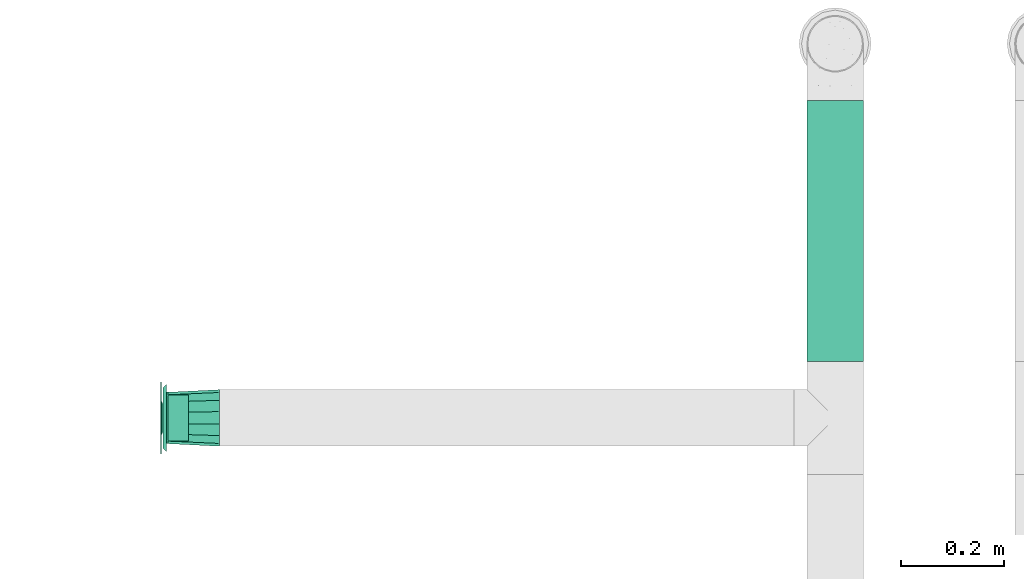
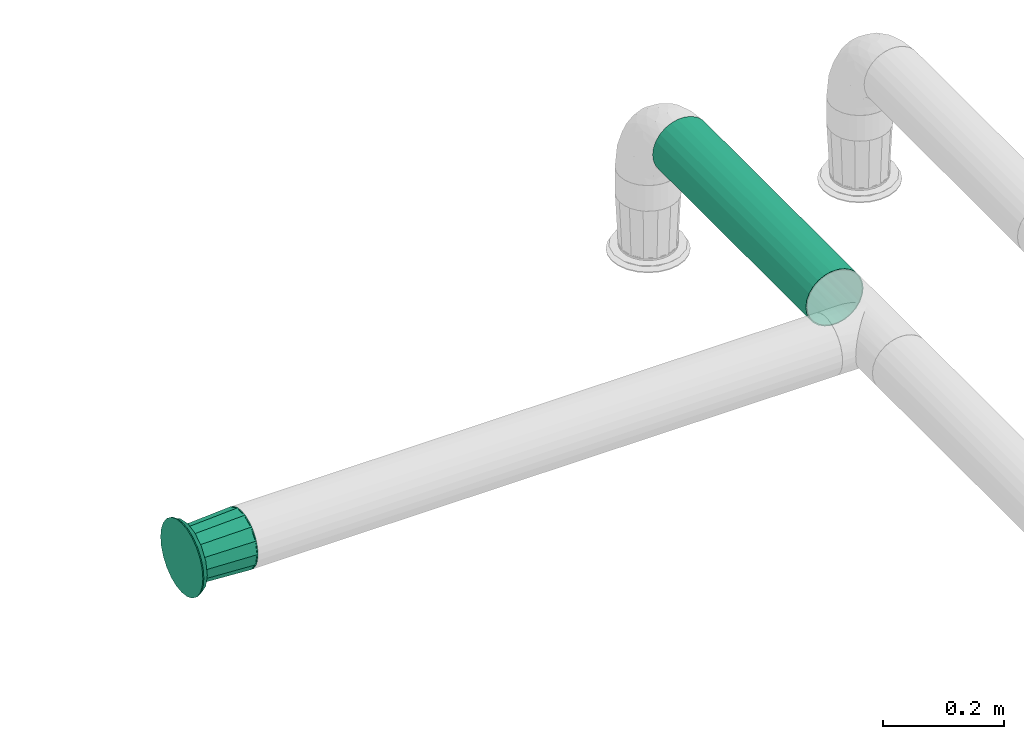
# One storey, part 30 of 115: 1 flow fitting, 1 flow segment, 1 flow terminal.
"""IFC2X3 building model written with IfcOpenShell, lengths in millimetres."""

from ifc_helpers import new_model, entity, si_unit, converted_unit, derived_unit, direction, frame, origin_with_axes, origin_2d_with_axis, place, context, subcontext, project, spatial, hollow_circle, extrude, open_shell, surface_model, source, transform, mapped, material, layer, layer_set, layer_usage, type_object, element, save


model = new_model("IFC2X3")

# Units and contexts
model_context = context("Model", 3, precision=1e-05, world=origin_with_axes(), true_north=direction((0.0, 1.0)))
body_context = subcontext(model_context, "Body", "Model", "MODEL_VIEW")
ifc_project = project(units=[si_unit("AREAUNIT", "SQUARE_METRE"), si_unit("VOLUMEUNIT", "CUBIC_METRE", prefix="DECI"), si_unit("TIMEUNIT", "SECOND"), si_unit("THERMODYNAMICTEMPERATUREUNIT", "DEGREE_CELSIUS"), si_unit("PRESSUREUNIT", "PASCAL"), si_unit("MASSUNIT", "GRAM", prefix="KILO"), si_unit("LENGTHUNIT", "METRE", prefix="MILLI"), si_unit("POWERUNIT", "WATT"), si_unit("ELECTRICCURRENTUNIT", "AMPERE"), si_unit("ELECTRICVOLTAGEUNIT", "VOLT"), derived_unit("VOLUMETRICFLOWRATEUNIT", [(si_unit("VOLUMEUNIT", "CUBIC_METRE", prefix="DECI"), 1), (si_unit("TIMEUNIT", "SECOND"), -1)]), derived_unit("LINEARVELOCITYUNIT", [(si_unit("LENGTHUNIT", "METRE"), 1), (si_unit("TIMEUNIT", "SECOND"), -1)]), derived_unit("MASSDENSITYUNIT", [(si_unit("MASSUNIT", "GRAM", prefix="KILO"), 1), (si_unit("VOLUMEUNIT", "CUBIC_METRE"), -1)]), converted_unit("PLANEANGLEUNIT", "DEGREE", entity("IfcRatioMeasure", 0.01745), si_unit("PLANEANGLEUNIT", "RADIAN"), dimensions=[0, 0, 0, 0, 0, 0, 0])], contexts=[model_context])

# Site, building, storey
site_placement = place(None, origin_with_axes())
site = spatial("IfcSite", under=ifc_project, at=site_placement, CompositionType="ELEMENT")
building_placement = place(site_placement, origin_with_axes())
building = spatial("IfcBuilding", under=site, at=building_placement, Name="mc-building", CompositionType="ELEMENT")
storey_placement = place(building_placement, frame((0.0, 0.0, 2950.0), z_axis=(0.0, 0.0, 1.0), x_axis=(1.0, 0.0, 0.0)))
storey = spatial("IfcBuildingStorey", under=building, at=storey_placement, Name="2. Korrus", CompositionType="ELEMENT", Elevation=2950.0)

# Flow terminal
air_terminal_type = type_object("IfcAirTerminalType", Name="100", PredefinedType="NOTDEFINED")
shared_shape_1 = source(origin_with_axes(), body_context, "Body", "SurfaceModel", [
    surface_model("IfcShellBasedSurfaceModel", [(11.2, -70.0, 0.0), (11.2, -67.61481, -18.11733), (11.2, -67.61481, 18.11733), (6.2, -14.64625, -20.15883), (9.2, -22.36867, -22.36867), (6.2, -21.19625, -15.39997), (9.2, 16.375, -28.36233), (6.2, 8.09625, -24.91768), (6.2, 14.64625, -20.15883), (6.2, -8.09625, -24.91768), (9.2, -16.375, -28.36233), (6.2, 21.19625, -15.39997), (9.2, 22.36867, -22.36867), (9.2, -8.1875, -30.55617), (9.2, 8.1875, -30.55617), (9.2, 28.36233, -16.375), (9.2, -28.36233, -16.375), (6.2, 14.64625, 20.15883), (9.2, 22.36867, 22.36867), (6.2, 21.19625, 15.39997), (9.2, -16.375, 28.36233), (6.2, -8.09625, 24.91768), (6.2, -14.64625, 20.15883), (6.2, 8.09625, 24.91768), (9.2, 16.375, 28.36233), (6.2, -21.19625, 15.39997), (9.2, -22.36867, 22.36867), (9.2, 8.1875, 30.55617), (9.2, -8.1875, 30.55617), (9.2, -28.36233, 16.375), (9.2, 28.36233, 16.375), (6.2, -53.11211, -25.57744), (6.2, -36.75472, -46.08897), (6.2, -13.11761, -57.472), (6.2, 13.11761, -57.472), (6.2, 36.75472, -46.08897), (6.2, 53.11211, -25.57744), (0.0, -12.53288, -63.00706), (6.2, 0.0, -57.472), (0.0, -46.3155, -46.3155), (0.0, -35.69063, -53.4148), (0.0, 0.0, -65.5), (6.2, 44.93342, -35.83321), (0.0, 46.3155, -46.3155), (0.0, 35.69063, -53.4148), (6.2, -44.93342, -35.83321), (0.0, 12.53288, -63.00706), (0.0, 25.06576, -60.51411), (6.2, 56.03105, -12.78872), (0.0, 60.51411, -25.06576), (0.0, 63.00706, -12.53288), (0.0, 53.4148, -35.69063), (0.0, -25.06576, -60.51411), (0.0, -63.00706, -12.53288), (0.0, -60.51411, -25.06576), (6.2, -56.03105, -12.78872), (0.0, -53.4148, -35.69063), (6.2, 13.11761, 57.472), (0.0, 12.53288, 63.00706), (6.2, 0.0, 57.472), (6.2, 36.75472, 46.08897), (0.0, 46.3155, 46.3155), (0.0, 35.69063, 53.4148), (0.0, 0.0, 65.5), (6.2, -44.93342, 35.83321), (6.2, -36.75472, 46.08897), (0.0, -46.3155, 46.3155), (0.0, -35.69063, 53.4148), (6.2, 44.93342, 35.83321), (0.0, -12.53288, 63.00706), (0.0, -25.06576, 60.51411), (6.2, -13.11761, 57.472), (6.2, -56.03105, 12.78872), (0.0, -60.51411, 25.06576), (0.0, -63.00706, 12.53288), (0.0, -53.4148, 35.69063), (0.0, 25.06576, 60.51411), (0.0, 63.00706, 12.53288), (0.0, 60.51411, 25.06576), (6.2, 56.03105, 12.78872), (0.0, 53.4148, 35.69063), (-3.1, 43.30127, 25.0), (-3.1, -48.29629, -12.94095), (-3.1, -43.30127, 25.0), (-3.1, 25.0, -43.30127), (-3.1, 48.29629, -12.94095), (-3.1, 35.35534, -35.35534), (-3.1, -35.35534, -35.35534), (-3.1, -25.0, -43.30127), (-43.1, 43.46666, 11.64686), (-3.1, 38.97115, 22.5), (-3.1, 43.46666, 11.64686), (-3.1, 45.0, 0.0), (-43.1, 45.0, 0.0), (-3.1, 31.81981, 31.81981), (-43.1, 38.97115, 22.5), (-43.1, -38.97115, 22.5), (-3.1, -38.97115, 22.5), (-3.1, -31.81981, 31.81981), (-3.1, -43.46666, 11.64686), (-43.1, -43.46666, 11.64686), (-43.1, -45.0, 0.0), (-3.1, -45.0, 0.0), (-43.1, -43.46666, -11.64686), (-3.1, -38.97115, -22.5), (-3.1, -43.46666, -11.64686), (-3.1, -11.64686, -43.46666), (-3.1, -22.5, -38.97115), (-43.1, -22.5, -38.97115), (-3.1, -31.81981, -31.81981), (-43.1, -38.97115, -22.5), (-43.1, 22.5, -38.97115), (-3.1, 22.5, -38.97115), (-3.1, 11.64686, -43.46666), (-43.1, 38.97115, -22.5), (-3.1, 38.97115, -22.5), (-3.1, 31.81981, -31.81981), (-3.1, 43.46666, -11.64686), (-43.1, 43.46666, -11.64686), (11.2, -49.49747, -49.49747), (11.2, -35.0, -60.62178), (11.2, -18.11733, -67.61481), (11.2, 67.61481, 18.11733), (11.2, -60.62178, -35.0), (11.2, 18.11733, -67.61481), (11.2, 35.0, -60.62178), (11.2, 0.0, -70.0), (11.2, 60.62178, -35.0), (11.2, 67.61481, -18.11733), (11.2, 49.49747, -49.49747), (11.2, -49.49747, 49.49747), (11.2, -60.62178, 35.0), (11.2, -35.0, 60.62178), (11.2, -18.11733, 67.61481), (11.2, 0.0, 70.0), (11.2, 60.62178, 35.0), (11.2, 49.49747, 49.49747), (11.2, 70.0, 0.0), (11.2, 35.0, 60.62178), (11.2, 18.11733, 67.61481), (9.2, -49.49747, 49.49747), (9.2, -35.0, 60.62178), (9.2, -18.11733, 67.61481), (9.2, -67.61481, 18.11733), (9.2, -70.0, 0.0), (9.2, -60.62178, 35.0), (9.2, 67.61481, 18.11733), (9.2, 35.0, 60.62178), (9.2, 18.11733, 67.61481), (9.2, 0.0, 70.0), (9.2, 60.62178, 35.0), (9.2, 49.49747, 49.49747), (9.2, -67.61481, -18.11733), (9.2, -49.49747, -49.49747), (9.2, -60.62178, -35.0), (9.2, -18.11733, -67.61481), (9.2, 70.0, 0.0), (9.2, -35.0, -60.62178), (9.2, 0.0, -70.0), (9.2, 60.62178, -35.0), (9.2, 49.49747, -49.49747), (9.2, 67.61481, -18.11733), (9.2, 35.0, -60.62178), (9.2, 18.11733, -67.61481), (9.2, -32.75, 0.0), (9.2, 0.0, 32.75), (9.2, 32.75, 0.0), (9.2, 0.0, -32.75), (6.2, 26.2, 0.0), (6.2, -26.2, 0.0), (9.2, -31.06579, -6.28555), (6.2, -23.69812, -7.69999), (6.2, 23.69812, -7.69999), (9.2, 31.06579, -6.28555), (6.2, 0.0, -24.91768), (9.2, 31.06579, 6.28555), (6.2, 23.69812, 7.69999), (6.2, -23.69812, 7.69999), (9.2, -31.06579, 6.28555), (6.2, 0.0, 24.91768), (6.2, 53.11211, 25.57744), (6.2, 58.95, 0.0), (6.2, -53.11211, 25.57744), (6.2, -58.95, 0.0), (0.0, 65.5, 0.0), (0.0, -65.5, 0.0), (6.2, -24.93616, -51.78048), (6.2, 24.93616, -51.78048), (6.2, 24.93616, 51.78048), (6.2, -24.93616, 51.78048), (-3.1, 0.0, 50.0), (-3.1, 35.35534, 35.35534), (-3.1, -12.94095, 48.29629), (-3.1, -25.0, 43.30127), (-3.1, -35.35534, 35.35534), (-3.1, 25.0, 43.30127), (-3.1, 12.94095, 48.29629), (-3.1, 48.29629, 12.94095), (-3.1, 50.0, 0.0), (-3.1, -50.0, 0.0), (-3.1, -48.29629, 12.94095), (-3.1, -43.30127, -25.0), (-3.1, -12.94095, -48.29629), (-3.1, 0.0, -50.0), (-3.1, 43.30127, -25.0), (-3.1, 12.94095, -48.29629), (0.0, -12.94095, -48.29629), (0.0, 0.0, -50.0), (0.0, -25.0, -43.30127), (0.0, -35.35534, -35.35534), (0.0, -48.29629, -12.94095), (0.0, 25.0, -43.30127), (0.0, -43.30127, -25.0), (0.0, 43.30127, 25.0), (0.0, 12.94095, -48.29629), (0.0, 43.30127, -25.0), (0.0, 48.29629, -12.94095), (0.0, 35.35534, -35.35534), (0.0, 50.0, 0.0), (0.0, -50.0, 0.0), (0.0, -48.29629, 12.94095), (0.0, -43.30127, 25.0), (0.0, -35.35534, 35.35534), (0.0, -12.94095, 48.29629), (0.0, -25.0, 43.30127), (0.0, 35.35534, 35.35534), (0.0, 0.0, 50.0), (0.0, 48.29629, 12.94095), (0.0, 25.0, 43.30127), (0.0, 12.94095, 48.29629), (-43.1, -22.5, 38.97115), (-43.1, -11.64686, 43.46666), (-43.1, 0.0, 45.0), (-43.1, 11.64686, 43.46666), (-43.1, -31.81981, 31.81981), (-43.1, 31.81981, 31.81981), (-43.1, 22.5, 38.97115), (-43.1, -31.81981, -31.81981), (-43.1, 31.81981, -31.81981), (-43.1, -11.64686, -43.46666), (-43.1, 11.64686, -43.46666), (-43.1, 0.0, -45.0), (-3.1, 0.0, -45.0), (-3.1, 0.0, 45.0), (-3.1, -22.5, 38.97115), (-3.1, -11.64686, 43.46666), (-3.1, 11.64686, 43.46666), (-3.1, 22.5, 38.97115)], [open_shell([[[0, 1, 2]], [[3, 4, 5]], [[6, 7, 8]], [[3, 9, 10]], [[4, 3, 10]], [[11, 12, 8]], [[13, 10, 9]], [[7, 6, 14]], [[6, 8, 12]], [[12, 11, 15]], [[16, 5, 4]], [[17, 18, 19]], [[20, 21, 22]], [[17, 23, 24]], [[18, 17, 24]], [[25, 26, 22]], [[27, 24, 23]], [[21, 20, 28]], [[20, 22, 26]], [[26, 25, 29]], [[30, 19, 18]], [[31, 32, 33]], [[34, 35, 36]], [[33, 37, 38]], [[32, 39, 40]], [[41, 38, 37]], [[42, 35, 43]], [[44, 43, 35]], [[39, 32, 45]], [[46, 47, 34]], [[48, 49, 50]], [[38, 46, 34]], [[42, 43, 51]], [[33, 52, 37]], [[53, 54, 55]], [[46, 38, 41]], [[56, 39, 45]], [[57, 58, 59]], [[60, 61, 62]], [[63, 59, 58]], [[64, 65, 66]], [[67, 66, 65]], [[61, 60, 68]], [[69, 70, 71]], [[72, 73, 74]], [[59, 69, 71]], [[64, 66, 75]], [[57, 76, 58]], [[77, 78, 79]], [[69, 59, 63]], [[80, 61, 68]], [[81, 82, 83]], [[84, 85, 86]], [[87, 82, 88]], [[89, 90, 91]], [[91, 92, 93]], [[94, 90, 95]], [[96, 97, 98]], [[99, 97, 100]], [[101, 102, 99]], [[103, 104, 105]], [[105, 102, 101]], [[106, 107, 108]], [[109, 104, 110]], [[111, 112, 113]], [[114, 115, 116]], [[117, 115, 118]], [[93, 92, 117]], [[119, 120, 121]], [[1, 119, 121]], [[122, 1, 121]], [[123, 119, 1]], [[124, 122, 121]], [[125, 122, 124]], [[121, 126, 124]], [[127, 128, 129]], [[129, 128, 122]], [[129, 122, 125]], [[130, 131, 2]], [[132, 130, 2]], [[122, 133, 2]], [[132, 2, 133]], [[134, 133, 122]], [[135, 136, 122]], [[122, 128, 137]], [[136, 138, 122]], [[139, 122, 138]], [[122, 139, 134]], [[2, 1, 122]], [[140, 141, 142]], [[143, 140, 142]], [[142, 144, 143]], [[145, 140, 143]], [[146, 144, 142]], [[147, 146, 148]], [[149, 148, 146]], [[150, 146, 151]], [[147, 151, 146]], [[146, 142, 149]], [[146, 152, 144]], [[153, 154, 152]], [[155, 153, 152]], [[146, 156, 155]], [[157, 153, 155]], [[158, 155, 156]], [[159, 160, 161]], [[156, 161, 160]], [[160, 162, 156]], [[163, 156, 162]], [[163, 158, 156]], [[152, 146, 155]], [[156, 128, 161]], [[161, 127, 159]], [[162, 160, 125]], [[129, 160, 159]], [[163, 162, 124]], [[128, 127, 161]], [[156, 137, 128]], [[162, 125, 124]], [[125, 160, 129]], [[159, 127, 129]], [[163, 124, 126]], [[126, 158, 163]], [[158, 121, 155]], [[155, 120, 157]], [[154, 153, 123]], [[119, 153, 157]], [[152, 154, 1]], [[120, 119, 157]], [[155, 121, 120]], [[152, 1, 0]], [[1, 154, 123]], [[153, 119, 123]], [[152, 0, 144]], [[126, 121, 158]], [[144, 2, 143]], [[143, 131, 145]], [[141, 140, 132]], [[130, 140, 145]], [[142, 141, 133]], [[2, 131, 143]], [[144, 0, 2]], [[141, 132, 133]], [[132, 140, 130]], [[145, 131, 130]], [[142, 133, 134]], [[134, 149, 142]], [[149, 139, 148]], [[148, 138, 147]], [[150, 151, 135]], [[136, 151, 147]], [[146, 150, 122]], [[138, 136, 147]], [[148, 139, 138]], [[146, 122, 137]], [[122, 150, 135]], [[151, 136, 135]], [[146, 137, 156]], [[134, 139, 149]], [[30, 24, 164]], [[24, 20, 164]], [[165, 20, 24]], [[164, 20, 29]], [[166, 30, 16]], [[16, 6, 166]], [[167, 6, 10]], [[30, 164, 16]], [[10, 6, 16]], [[6, 15, 166]], [[21, 19, 11]], [[23, 19, 21]], [[11, 19, 168]], [[7, 25, 21]], [[7, 5, 169]], [[21, 11, 7]], [[9, 5, 7]], [[169, 25, 7]], [[170, 164, 169]], [[170, 171, 16]], [[11, 172, 15]], [[172, 168, 173]], [[174, 13, 9]], [[166, 173, 168]], [[172, 173, 15]], [[169, 171, 170]], [[5, 16, 171]], [[167, 174, 14]], [[174, 167, 13]], [[14, 174, 7]], [[175, 166, 168]], [[175, 176, 30]], [[25, 177, 29]], [[177, 169, 178]], [[179, 27, 23]], [[164, 178, 169]], [[177, 178, 29]], [[168, 176, 175]], [[19, 30, 176]], [[165, 179, 28]], [[179, 165, 27]], [[28, 179, 21]], [[180, 60, 57]], [[181, 180, 65]], [[65, 57, 71]], [[180, 57, 65]], [[65, 182, 181]], [[182, 36, 181]], [[183, 34, 36]], [[31, 34, 183]], [[31, 33, 34]], [[182, 183, 36]], [[70, 63, 49]], [[70, 73, 66]], [[49, 63, 184]], [[78, 76, 61]], [[76, 78, 184]], [[184, 63, 76]], [[73, 70, 49]], [[39, 54, 185]], [[41, 39, 185]], [[52, 39, 41]], [[43, 185, 49]], [[185, 43, 47]], [[185, 47, 41]], [[73, 49, 185]], [[55, 54, 31]], [[31, 54, 56]], [[52, 186, 40]], [[53, 55, 183]], [[56, 45, 31]], [[185, 53, 183]], [[32, 40, 186]], [[33, 186, 52]], [[44, 35, 187]], [[49, 36, 51]], [[34, 47, 187]], [[42, 51, 36]], [[187, 47, 44]], [[49, 48, 36]], [[48, 50, 181]], [[184, 181, 50]], [[79, 78, 180]], [[180, 78, 80]], [[76, 188, 62]], [[77, 79, 181]], [[80, 68, 180]], [[184, 77, 181]], [[60, 62, 188]], [[57, 188, 76]], [[67, 65, 189]], [[73, 182, 75]], [[71, 70, 189]], [[64, 75, 182]], [[189, 70, 67]], [[73, 72, 182]], [[72, 74, 183]], [[185, 183, 74]], [[190, 191, 192]], [[193, 192, 194]], [[83, 192, 81]], [[194, 192, 83]], [[195, 191, 196]], [[191, 190, 196]], [[197, 198, 81]], [[81, 192, 191]], [[198, 84, 81]], [[199, 200, 83]], [[81, 88, 82]], [[201, 82, 87]], [[88, 81, 202]], [[81, 203, 202]], [[204, 86, 85]], [[205, 203, 84]], [[84, 198, 85]], [[81, 84, 203]], [[199, 83, 82]], [[206, 207, 208]], [[209, 208, 210]], [[210, 208, 211]], [[212, 209, 210]], [[210, 211, 213]], [[214, 211, 207]], [[211, 208, 207]], [[215, 216, 217]], [[211, 217, 216]], [[216, 218, 211]], [[219, 210, 220]], [[221, 210, 213]], [[222, 221, 223]], [[213, 223, 221]], [[224, 222, 223]], [[223, 225, 226]], [[227, 213, 218]], [[218, 213, 211]], [[228, 229, 225]], [[223, 213, 225]], [[226, 225, 229]], [[221, 220, 210]], [[199, 220, 200]], [[200, 221, 83]], [[193, 194, 224]], [[222, 194, 83]], [[192, 193, 223]], [[220, 221, 200]], [[199, 219, 220]], [[193, 224, 223]], [[224, 194, 222]], [[83, 221, 222]], [[192, 223, 226]], [[226, 190, 192]], [[190, 229, 196]], [[196, 228, 195]], [[81, 191, 213]], [[225, 191, 195]], [[197, 81, 227]], [[228, 225, 195]], [[196, 229, 228]], [[197, 227, 218]], [[227, 81, 213]], [[191, 225, 213]], [[197, 218, 198]], [[226, 229, 190]], [[198, 216, 85]], [[85, 215, 204]], [[84, 86, 211]], [[217, 86, 204]], [[205, 84, 214]], [[216, 215, 85]], [[198, 218, 216]], [[84, 211, 214]], [[211, 86, 217]], [[204, 215, 217]], [[205, 214, 207]], [[207, 203, 205]], [[203, 206, 202]], [[202, 208, 88]], [[201, 87, 212]], [[209, 87, 88]], [[82, 201, 210]], [[208, 209, 88]], [[202, 206, 208]], [[82, 210, 219]], [[210, 201, 212]], [[87, 209, 212]], [[82, 219, 199]], [[207, 206, 203]], [[230, 231, 232]], [[230, 232, 233]], [[230, 100, 96]], [[234, 230, 96]], [[100, 230, 233]], [[235, 89, 236]], [[100, 233, 236]], [[95, 89, 235]], [[118, 89, 93]], [[118, 236, 89]], [[118, 100, 236]], [[110, 103, 101]], [[237, 110, 101]], [[238, 108, 101]], [[237, 101, 108]], [[239, 108, 238]], [[114, 238, 118]], [[238, 101, 118]], [[240, 241, 111]], [[238, 111, 241]], [[238, 241, 239]], [[100, 118, 101]], [[106, 242, 107]], [[107, 112, 109]], [[102, 105, 104]], [[112, 104, 109]], [[92, 104, 117]], [[113, 112, 242]], [[112, 107, 242]], [[115, 117, 116]], [[112, 116, 117]], [[112, 117, 104]], [[92, 102, 104]], [[97, 99, 243]], [[98, 97, 244]], [[243, 245, 244]], [[97, 243, 244]], [[246, 243, 99]], [[90, 94, 91]], [[92, 91, 247]], [[94, 247, 91]], [[247, 99, 92]], [[247, 246, 99]], [[102, 92, 99]], [[101, 99, 100]], [[100, 97, 96]], [[230, 234, 244]], [[98, 234, 96]], [[231, 230, 245]], [[245, 230, 244]], [[244, 234, 98]], [[245, 243, 231]], [[243, 232, 231]], [[236, 233, 246]], [[236, 247, 235]], [[89, 95, 90]], [[94, 95, 235]], [[93, 89, 91]], [[232, 246, 233]], [[246, 247, 236]], [[243, 246, 232]], [[247, 94, 235]], [[93, 117, 118]], [[118, 115, 114]], [[111, 238, 112]], [[116, 238, 114]], [[240, 111, 113]], [[112, 238, 116]], [[240, 113, 242]], [[242, 241, 240]], [[108, 239, 106]], [[108, 107, 237]], [[103, 110, 104]], [[109, 110, 237]], [[101, 103, 105]], [[241, 106, 239]], [[242, 106, 241]], [[107, 109, 237]]])]),
])
flow_terminal_placement = place(storey_placement, frame((14495.97051, 3666.26111, 2465.0), z_axis=(0.0, 0.0, 1.0), x_axis=(-1.0, 0.0, 0.0)))
element("IfcFlowTerminal", 1, at=flow_terminal_placement, inside=storey, type_object=air_terminal_type, Name="100", context=body_context, shape_type="MappedRepresentation", body=[
    mapped(shared_shape_1, transform((0.0, 0.0, 0.0), scale=1.0)),
])

# Flow fitting
duct_fitting_type = type_object("IfcDuctFittingType", PredefinedType="TRANSITION")
shared_shape_2 = source(origin_with_axes(), body_context, "Body", "SurfaceModel", [
    surface_model("IfcShellBasedSurfaceModel", [(100.0, -55.0, 0.0), (100.0, -12.23865, 53.62104), (100.0, -34.29194, 43.00073), (100.0, 49.55329, 23.86361), (100.0, 34.29194, 43.00073), (100.0, 49.55329, -23.86361), (0.0, -45.04844, -21.69419), (0.0, -50.0, 0.0), (0.0, -45.04844, 21.69419), (0.0, 31.17449, 39.09157), (0.0, 45.04844, 21.69419), (0.0, 50.0, 0.0), (98.0, 47.63139, 27.5), (98.0, 0.0, 55.0), (98.0, 38.89087, 38.89087), (98.0, -38.89087, 38.89087), (98.0, -47.63139, 27.5), (100.0, 12.23865, 53.62104), (100.0, -49.55329, 23.86361), (100.0, 55.0, 0.0), (100.0, 12.23865, -53.62104), (100.0, 34.29194, -43.00073), (100.0, -49.55329, -23.86361), (100.0, -34.29194, -43.00073), (100.0, -12.23865, -53.62104), (0.0, -31.17449, 39.09157), (0.0, -11.12605, 48.7464), (0.0, 11.12605, 48.7464), (0.0, -31.17449, -39.09157), (0.0, 11.12605, -48.7464), (0.0, -11.12605, -48.7464), (0.0, 45.04844, -21.69419), (0.0, 31.17449, -39.09157), (0.0, 47.52422, -10.84709), (0.0, 38.11147, -30.39288), (100.0, 41.92261, -33.43217), (100.0, -41.92261, -33.43217), (0.0, -38.11147, -30.39288), (100.0, 23.2653, -48.31088), (0.0, 21.15027, -43.91899), (100.0, 52.32388, -11.72483), (0.0, 0.0, -48.7464), (100.0, 0.0, -53.62104), (0.0, -21.15027, -43.91899), (100.0, -23.2653, -48.31088), (0.0, -47.52422, -10.84709), (100.0, -52.32388, -11.72483), (0.0, -47.52422, 10.84709), (0.0, -38.11147, 30.39288), (100.0, -41.92261, 33.43217), (100.0, 41.92261, 33.43217), (0.0, 38.11147, 30.39288), (100.0, -23.2653, 48.31088), (0.0, -21.15027, 43.91899), (100.0, -52.32388, 11.72483), (0.0, 0.0, 48.7464), (100.0, 0.0, 53.62104), (0.0, 21.15027, 43.91899), (100.0, 23.2653, 48.31088), (0.0, 47.52422, 10.84709), (100.0, 52.32388, 11.72483), (100.0, -14.23505, -53.12592), (100.0, 0.0, -55.0), (100.0, -27.5, -47.63139), (100.0, 27.5, -47.63139), (100.0, -38.89087, -38.89087), (100.0, -53.12592, -14.23505), (100.0, -47.63139, -27.5), (100.0, -47.63139, 27.5), (100.0, 14.23505, -53.12592), (100.0, 38.89087, -38.89087), (100.0, 47.63139, -27.5), (100.0, 47.63139, 27.5), (100.0, 53.12592, -14.23505), (100.0, -53.12592, 14.23505), (100.0, -38.89087, 38.89087), (100.0, -27.5, 47.63139), (100.0, 0.0, 55.0), (100.0, -14.23505, 53.12592), (100.0, 53.12592, 14.23505), (100.0, 38.89087, 38.89087), (100.0, 27.5, 47.63139), (100.0, 14.23505, 53.12592), (98.0, -27.5, 47.63139), (98.0, -14.23505, 53.12592), (98.0, -53.12592, -14.23505), (98.0, 14.23505, 53.12592), (98.0, 27.5, 47.63139), (98.0, 53.12592, 14.23505), (98.0, 55.0, 0.0), (98.0, -47.63139, -27.5), (98.0, -53.12592, 14.23505), (98.0, 27.5, -47.63139), (98.0, -27.5, -47.63139), (98.0, -38.89087, -38.89087), (98.0, 0.0, -55.0), (98.0, -14.23505, -53.12592), (98.0, 38.89087, -38.89087), (98.0, 47.63139, -27.5), (98.0, 53.12592, -14.23505), (98.0, 14.23505, -53.12592), (98.0, -55.0, 0.0), (0.0, 0.0, 50.0), (0.0, 35.35534, 35.35534), (0.0, -12.94095, 48.29629), (0.0, -25.0, 43.30127), (0.0, -35.35534, 35.35534), (0.0, -48.29629, 12.94095), (0.0, -43.30127, 25.0), (0.0, 25.0, 43.30127), (0.0, 12.94095, 48.29629), (0.0, 43.30127, 25.0), (0.0, 48.29629, 12.94095), (0.0, 25.0, -43.30127), (0.0, 48.29629, -12.94095), (0.0, -48.29629, -12.94095), (0.0, -43.30127, -25.0), (0.0, -12.94095, -48.29629), (0.0, -25.0, -43.30127), (0.0, -35.35534, -35.35534), (0.0, 43.30127, -25.0), (0.0, 35.35534, -35.35534), (0.0, 12.94095, -48.29629), (0.0, 0.0, -50.0), (2.0, -35.35534, -35.35534), (2.0, -25.0, -43.30127), (2.0, -12.94095, -48.29629), (2.0, -43.30127, -25.0), (2.0, 0.0, -50.0), (2.0, -48.29629, -12.94095), (2.0, -50.0, 0.0), (2.0, 12.94095, -48.29629), (2.0, 25.0, -43.30127), (2.0, 43.30127, -25.0), (2.0, 48.29629, -12.94095), (2.0, 35.35534, -35.35534), (2.0, -48.29629, 12.94095), (2.0, -35.35534, 35.35534), (2.0, -43.30127, 25.0), (2.0, 35.35534, 35.35534), (2.0, -12.94095, 48.29629), (2.0, -25.0, 43.30127), (2.0, 0.0, 50.0), (2.0, 43.30127, 25.0), (2.0, 48.29629, 12.94095), (2.0, 50.0, 0.0), (2.0, 25.0, 43.30127), (2.0, 12.94095, 48.29629)], [open_shell([[[0, 1, 2]], [[3, 4, 5]], [[6, 7, 8]], [[9, 10, 11]], [[12, 13, 14]], [[15, 13, 16]], [[0, 4, 17]], [[2, 18, 0]], [[1, 0, 17]], [[3, 5, 19]], [[20, 21, 5]], [[22, 20, 5]], [[22, 5, 0]], [[22, 23, 24]], [[22, 24, 20]], [[4, 0, 5]], [[8, 25, 6]], [[6, 25, 26]], [[6, 26, 27]], [[11, 27, 9]], [[28, 6, 29]], [[30, 28, 29]], [[31, 6, 11]], [[31, 32, 29]], [[31, 29, 6]], [[27, 11, 6]], [[31, 33, 5]], [[34, 35, 32]], [[36, 22, 6]], [[36, 37, 23]], [[38, 29, 39]], [[33, 40, 5]], [[33, 11, 40]], [[19, 40, 11]], [[32, 21, 39]], [[32, 35, 21]], [[34, 31, 35]], [[30, 41, 42]], [[28, 43, 44]], [[42, 41, 20]], [[7, 45, 46]], [[38, 39, 21]], [[46, 0, 7]], [[6, 37, 36]], [[38, 20, 29]], [[43, 30, 24]], [[42, 24, 30]], [[28, 23, 37]], [[6, 22, 45]], [[35, 31, 5]], [[44, 43, 24]], [[20, 41, 29]], [[46, 45, 22]], [[44, 23, 28]], [[8, 47, 18]], [[48, 49, 25]], [[50, 3, 10]], [[50, 51, 4]], [[52, 26, 53]], [[47, 54, 18]], [[47, 7, 54]], [[0, 54, 7]], [[25, 2, 53]], [[25, 49, 2]], [[48, 8, 49]], [[27, 55, 56]], [[9, 57, 58]], [[56, 55, 1]], [[11, 59, 60]], [[52, 53, 2]], [[60, 19, 11]], [[10, 51, 50]], [[52, 1, 26]], [[57, 27, 17]], [[56, 17, 27]], [[9, 4, 51]], [[10, 3, 59]], [[49, 8, 18]], [[58, 57, 17]], [[1, 55, 26]], [[60, 59, 3]], [[58, 4, 9]], [[61, 62, 63]], [[63, 64, 65]], [[66, 67, 68]], [[65, 64, 67]], [[67, 64, 68]], [[69, 64, 62]], [[64, 63, 62]], [[70, 71, 64]], [[72, 64, 71]], [[71, 73, 19]], [[74, 0, 66]], [[72, 68, 64]], [[75, 68, 76]], [[77, 78, 76]], [[72, 76, 68]], [[76, 72, 77]], [[79, 72, 19]], [[19, 72, 71]], [[80, 81, 77]], [[77, 72, 80]], [[82, 77, 81]], [[74, 66, 68]], [[83, 84, 13]], [[15, 83, 13]], [[12, 16, 13]], [[16, 12, 85]], [[86, 87, 13]], [[87, 14, 13]], [[88, 89, 12]], [[89, 90, 12]], [[91, 16, 85]], [[90, 85, 12]], [[89, 92, 90]], [[93, 94, 95]], [[95, 94, 90]], [[96, 93, 95]], [[97, 92, 98]], [[98, 89, 99]], [[100, 95, 92]], [[92, 89, 98]], [[90, 92, 95]], [[101, 91, 85]], [[89, 73, 99]], [[99, 71, 98]], [[92, 97, 64]], [[70, 97, 98]], [[100, 92, 69]], [[73, 71, 99]], [[89, 19, 73]], [[92, 64, 69]], [[64, 97, 70]], [[98, 71, 70]], [[100, 69, 62]], [[62, 95, 100]], [[95, 61, 96]], [[96, 63, 93]], [[90, 94, 67]], [[65, 94, 93]], [[85, 90, 66]], [[63, 65, 93]], [[96, 61, 63]], [[85, 66, 0]], [[66, 90, 67]], [[94, 65, 67]], [[85, 0, 101]], [[62, 61, 95]], [[101, 74, 91]], [[91, 68, 16]], [[83, 15, 76]], [[75, 15, 16]], [[84, 83, 78]], [[74, 68, 91]], [[101, 0, 74]], [[83, 76, 78]], [[76, 15, 75]], [[16, 68, 75]], [[84, 78, 77]], [[77, 13, 84]], [[13, 82, 86]], [[86, 81, 87]], [[12, 14, 72]], [[80, 14, 87]], [[88, 12, 79]], [[81, 80, 87]], [[86, 82, 81]], [[88, 79, 19]], [[79, 12, 72]], [[14, 80, 72]], [[88, 19, 89]], [[77, 82, 13]], [[102, 103, 104]], [[105, 104, 106]], [[107, 108, 106]], [[103, 106, 104]], [[106, 103, 107]], [[109, 103, 110]], [[103, 102, 110]], [[111, 112, 103]], [[113, 103, 112]], [[112, 11, 114]], [[107, 103, 113]], [[113, 115, 107]], [[116, 115, 117]], [[117, 118, 119]], [[116, 117, 119]], [[117, 115, 113]], [[120, 121, 114]], [[113, 114, 121]], [[113, 122, 117]], [[113, 112, 114]], [[117, 122, 123]], [[7, 107, 115]], [[124, 125, 126]], [[127, 124, 126]], [[128, 129, 126]], [[127, 126, 129]], [[130, 129, 128]], [[131, 132, 128]], [[132, 130, 128]], [[133, 134, 135]], [[132, 135, 134]], [[132, 134, 130]], [[134, 136, 130]], [[137, 138, 136]], [[137, 136, 139]], [[140, 137, 139]], [[141, 137, 140]], [[142, 140, 139]], [[143, 139, 144]], [[144, 134, 145]], [[146, 147, 139]], [[139, 136, 144]], [[139, 147, 142]], [[136, 134, 144]], [[11, 134, 114]], [[114, 133, 120]], [[113, 121, 132]], [[135, 121, 120]], [[122, 113, 131]], [[134, 133, 114]], [[11, 145, 134]], [[113, 132, 131]], [[132, 121, 135]], [[120, 133, 135]], [[122, 131, 128]], [[128, 123, 122]], [[123, 126, 117]], [[117, 125, 118]], [[116, 119, 127]], [[124, 119, 118]], [[115, 116, 129]], [[125, 124, 118]], [[117, 126, 125]], [[115, 129, 130]], [[129, 116, 127]], [[119, 124, 127]], [[115, 130, 7]], [[128, 126, 123]], [[7, 136, 107]], [[107, 138, 108]], [[105, 106, 141]], [[137, 106, 108]], [[104, 105, 140]], [[136, 138, 107]], [[7, 130, 136]], [[105, 141, 140]], [[141, 106, 137]], [[108, 138, 137]], [[104, 140, 142]], [[142, 102, 104]], [[102, 147, 110]], [[110, 146, 109]], [[111, 103, 143]], [[139, 103, 109]], [[112, 111, 144]], [[146, 139, 109]], [[110, 147, 146]], [[112, 144, 145]], [[144, 111, 143]], [[103, 139, 143]], [[112, 145, 11]], [[142, 147, 102]]])]),
])
flow_fitting_placement = place(storey_placement, frame((14499.07051, 3666.26111, 2465.0), z_axis=(0.0, 0.0, 1.0), x_axis=(1.0, 0.0, 0.0)))
element("IfcFlowFitting", 2, at=flow_fitting_placement, inside=storey, type_object=duct_fitting_type, context=body_context, shape_type="MappedRepresentation", body=[
    mapped(shared_shape_2, transform((0.0, 0.0, 0.0), scale=1.0)),
])

# Flow segment
ifc_material = material(Name="FZ1")
ifc_layer = layer(ifc_material, 0.0)
ifc_layer_set = layer_set([ifc_layer], Name="FZ1")
ifc_layer_usage = layer_usage(ifc_layer_set, "AXIS1", "POSITIVE", 0.0)
duct_segment_type = type_object("IfcDuctSegmentType", PredefinedType="RIGIDSEGMENT")
shared_shape_3 = source(origin_with_axes(), body_context, "Body", "SweptSolid", [
    extrude(hollow_circle(Radius=55.0, WallThickness=2.0, at=origin_2d_with_axis()), frame((0.0, 0.0, 0.0), z_axis=(1.0, 0.0, 0.0), x_axis=(0.0, 1.0, 0.0)), (0.0, 0.0, 1.0), 507.6),
])
flow_segment_placement = place(storey_placement, frame((15796.4103, 3776.26111, 2465.0), z_axis=(0.0, 0.0, 1.0), x_axis=(0.0, 1.0, 0.0)))
element("IfcFlowSegment", 3, at=flow_segment_placement, inside=storey, type_object=duct_segment_type, material=ifc_layer_usage, context=body_context, shape_type="MappedRepresentation", body=[
    mapped(shared_shape_3, transform((0.0, 0.0, 0.0), scale=1.0)),
])

save(model, "model.ifc")
